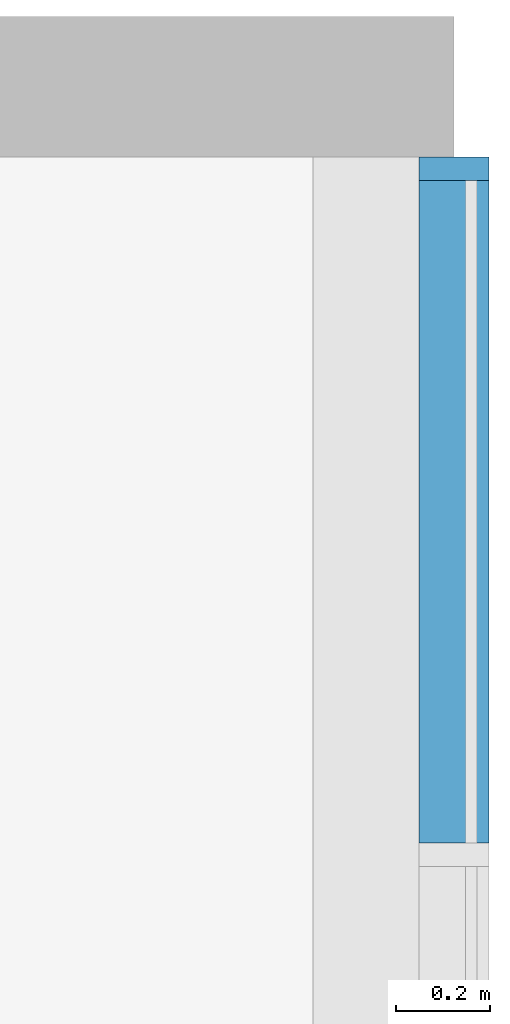
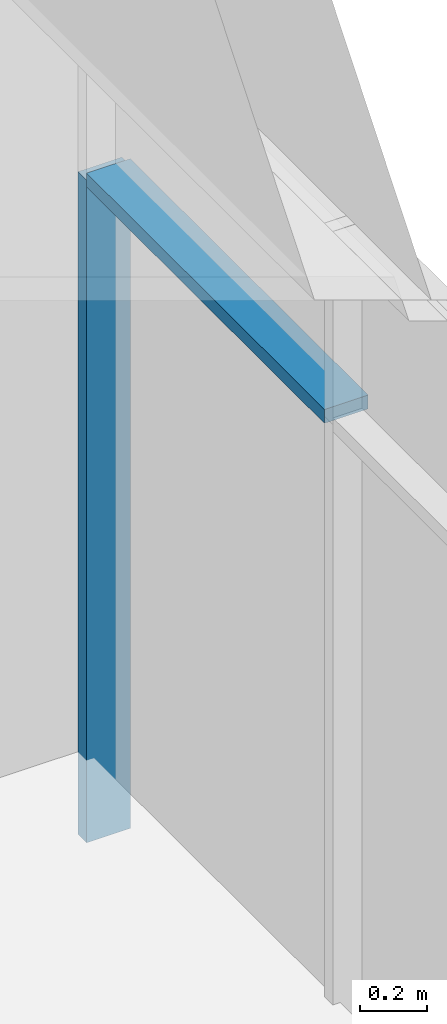
# One storey, part 3 of 13: 2 members, 1 element without a shape of its own.
"""IFC2X3 building model written with IfcOpenShell, lengths in millimetres."""

import ifcopenshell
import ifcopenshell.guid

model = None  # the IFC model being written
_history = None  # IfcOwnerHistory: only IFC2X3 demands one
_inside = {}  # id of a spatial element -> (the spatial element, [elements in it])
_under = {}  # id of a project, library or spatial element -> (it, [spatial elements below it])
_declared = {}  # id of a project -> (the project, [libraries it declares])
_typed = {}  # id of a type object -> (the type object, [elements of that type])
_made_of = {}  # id of a material, layer set ... -> (it, [elements and type objects made of it])


def new_model(schema):
    """Start an empty IFC model of exactly this schema.

    Asked for "IFC4X3", IfcOpenShell would pick the latest addendum, in which some entities
    have other attributes; the version numbers below select the first issue.
    IFC2X3 requires an IfcOwnerHistory on every rooted entity: one is made here for all.
    """
    global model, _history
    if schema == "IFC4X3":
        model = ifcopenshell.file(schema_version=(4, 3, 0, 0))
    else:
        model = ifcopenshell.file(schema=schema)
    _inside.clear()
    _under.clear()
    _declared.clear()
    _typed.clear()
    _made_of.clear()
    _history = None
    if model.schema == "IFC2X3":
        org = make("IfcOrganization", Name="unknown")
        user = make(
            "IfcPersonAndOrganization",
            ThePerson=make("IfcPerson", FamilyName="unknown"),
            TheOrganization=org,
        )
        app = make(
            "IfcApplication",
            ApplicationDeveloper=org,
            Version="unknown",
            ApplicationFullName="unknown",
            ApplicationIdentifier="unknown",
        )
        _history = make(
            "IfcOwnerHistory",
            OwningUser=user,
            OwningApplication=app,
            ChangeAction="ADDED",
            CreationDate=0,
        )
    return model


def make(cls, **values):
    """One entity of the class cls with the attributes given. An attribute that is None is left unset."""
    return model.create_entity(
        cls, **{name: value for name, value in values.items() if value is not None}
    )


def entity(cls, *values):
    """Any entity or typed value of the class cls, its attributes in the order of the schema. None: left unset."""
    e = model.create_entity(cls)
    for i, value in enumerate(values):
        if value is not None:
            e[i] = value
    return e


def rooted(cls, **values):
    """An entity with a GlobalId (a new one), such as an element, a storey or a relation."""
    return make(cls, GlobalId=ifcopenshell.guid.new(), OwnerHistory=_history, **values)


def si_unit(unit_type, name, prefix=None):
    """IfcSIUnit, for example si_unit("LENGTHUNIT", "METRE", prefix="MILLI")."""
    return make("IfcSIUnit", UnitType=unit_type, Prefix=prefix, Name=name)


def converted_unit(unit_type, name, factor, base, dimensions=None, offset=None):
    """IfcConversionBasedUnit, such as the inch: factor (a typed value) times the base unit."""
    return make(
        "IfcConversionBasedUnit"
        if offset is None
        else "IfcConversionBasedUnitWithOffset",
        ConversionOffset=offset,
        Dimensions=None
        if dimensions is None
        else entity("IfcDimensionalExponents", *dimensions),
        UnitType=unit_type,
        Name=name,
        ConversionFactor=make(
            "IfcMeasureWithUnit", ValueComponent=factor, UnitComponent=base
        ),
    )


def derived_unit(unit_type, elements):
    """IfcDerivedUnit: a product of units, each with its exponent."""
    return make(
        "IfcDerivedUnit",
        Elements=[
            make("IfcDerivedUnitElement", Unit=unit, Exponent=power)
            for unit, power in elements
        ],
        UnitType=unit_type,
    )


def assignment(units):
    """IfcUnitAssignment: the units of a project."""
    return None if units is None else make("IfcUnitAssignment", Units=units)


def point(xyz):
    """IfcCartesianPoint."""
    return None if xyz is None else make("IfcCartesianPoint", Coordinates=xyz)


def direction(xyz):
    """IfcDirection."""
    return None if xyz is None else make("IfcDirection", DirectionRatios=xyz)


def frame(location, z_axis=None, x_axis=None):
    """IfcAxis2Placement3D, a coordinate frame: its origin and axes. An axis left out is left unset."""
    return make(
        "IfcAxis2Placement3D",
        Location=point(location),
        Axis=direction(z_axis),
        RefDirection=direction(x_axis),
    )


def frame_2d(location, x_axis=None):
    """IfcAxis2Placement2D, a coordinate frame in the plane: its origin and x axis."""
    return make(
        "IfcAxis2Placement2D", Location=point(location), RefDirection=direction(x_axis)
    )


def origin():
    """The frame at (0, 0, 0) with its axes left unset."""
    return frame((0.0, 0.0, 0.0))


def origin_2d_with_axis():
    """The frame at (0, 0) in the plane with the x axis (1, 0) written out."""
    return frame_2d((0.0, 0.0), x_axis=(1.0, 0.0))


def place(relative_to, where):
    """IfcLocalPlacement: puts the frame where relative to a parent placement (None: the world)."""
    return make(
        "IfcLocalPlacement", PlacementRelTo=relative_to, RelativePlacement=where
    )


def context(
    kind, dimensions, precision=None, world=None, true_north=None, identifier=None
):
    """IfcGeometricRepresentationContext, for example the 3D "Model" context."""
    return make(
        "IfcGeometricRepresentationContext",
        ContextIdentifier=identifier,
        ContextType=kind,
        CoordinateSpaceDimension=dimensions,
        Precision=precision,
        WorldCoordinateSystem=world,
        TrueNorth=true_north,
    )


def subcontext(parent, identifier, kind, view, scale=None):
    """IfcGeometricRepresentationSubContext, for example "Body" below "Model"."""
    return make(
        "IfcGeometricRepresentationSubContext",
        ContextIdentifier=identifier,
        ContextType=kind,
        ParentContext=parent,
        TargetScale=scale,
        TargetView=view,
    )


def project(units=None, contexts=None):
    """IfcProject with its units and contexts."""
    return rooted(
        "IfcProject",
        Name="project",
        RepresentationContexts=contexts,
        UnitsInContext=assignment(units),
    )


def spatial(cls, under=None, at=None, **own):
    """A site, building, storey or space (cls), placed at a placement, below another one or the project."""
    s = rooted(cls, ObjectPlacement=at, **own)
    if under is not None:
        _under.setdefault(under.id(), (under, []))[1].append(s)
    return s


def profile(cls, at=None, kind="AREA", **sizes):
    """A parametric profile (cls). Its sizes go by their IFC names, for example OverallWidth=200.0."""
    return make(cls, ProfileType=kind, Position=at, **sizes)


def rectangle(**sizes):
    """IfcRectangleProfileDef."""
    return profile("IfcRectangleProfileDef", **sizes)


def extrude(swept, where, along, depth):
    """IfcExtrudedAreaSolid: the profile swept, set in the frame where, extruded along a direction by depth."""
    return make(
        "IfcExtrudedAreaSolid",
        SweptArea=swept,
        Position=where,
        ExtrudedDirection=direction(along),
        Depth=depth,
    )


def shape(context_of_items, identifier, shape_type, items):
    """IfcShapeRepresentation: the items that make up one representation, for example the "Body"."""
    return make(
        "IfcShapeRepresentation",
        ContextOfItems=context_of_items,
        RepresentationIdentifier=identifier,
        RepresentationType=shape_type,
        Items=items,
    )


def material(Name=None, Category=None):
    """IfcMaterial."""
    return make("IfcMaterial", Name=Name, Category=Category)


def made_of(thing, what):
    """Note that an element or type object is made of a material, layer set ...; save() writes the relation."""
    if what is not None:
        _made_of.setdefault(what.id(), (what, []))[1].append(thing)
    return thing


def type_object(cls, material=None, **own):
    """A type object (cls), such as IfcWallType, which elements share."""
    return made_of(rooted(cls, **own), material)


def element(
    cls,
    number,
    at=None,
    inside=None,
    cuts=None,
    type_object=None,
    material=None,
    context=None,
    identifier="Body",
    shape_type=None,
    held_by="IfcProductDefinitionShape",
    body=None,
    shapes=None,
    **own,
):
    """One element of the class cls, such as IfcWall. Its Tag is "e" and its number.

    at: its placement. inside: the storey or other place that contains it. cuts: it is an
    opening in that element (IfcRelVoidsElement). A single representation is given by context,
    identifier, shape_type and body (its items); several are given by shapes. held_by: the class
    of the entity that holds the representations. save() writes the other relations.
    """
    e = rooted(cls, Tag="e%d" % number, ObjectPlacement=at, **own)
    if body is not None:
        shapes = [shape(context, identifier, shape_type, body)]
    if shapes is not None:
        e.Representation = make(held_by, Representations=shapes)
    if inside is not None:
        _inside.setdefault(inside.id(), (inside, []))[1].append(e)
    if cuts is not None:
        rooted(
            "IfcRelVoidsElement", RelatingBuildingElement=cuts, RelatedOpeningElement=e
        )
    if type_object is not None:
        _typed.setdefault(type_object.id(), (type_object, []))[1].append(e)
    return made_of(e, material)


def aggregate(whole, parts):
    """IfcRelAggregates: a whole, such as a stair, and the parts it consists of."""
    return rooted("IfcRelAggregates", RelatingObject=whole, RelatedObjects=parts)


def save(model, path):
    """Write the relations noted so far, then the file.

    IfcRelAggregates (storeys below a building ...), IfcRelContainedInSpatialStructure (elements
    in a storey), IfcRelDefinesByType, IfcRelAssociatesMaterial and IfcRelDeclares: one each for
    every whole, place, type object, material and project.
    """
    for whole, parts in _under.values():
        aggregate(whole, parts)
    for where, things in _inside.values():
        rooted(
            "IfcRelContainedInSpatialStructure",
            RelatedElements=things,
            RelatingStructure=where,
        )
    for kind, things in _typed.values():
        rooted("IfcRelDefinesByType", RelatedObjects=things, RelatingType=kind)
    for what, things in _made_of.values():
        rooted("IfcRelAssociatesMaterial", RelatedObjects=things, RelatingMaterial=what)
    for by, libraries in _declared.values():
        rooted("IfcRelDeclares", RelatingContext=by, RelatedDefinitions=libraries)
    model.write(path)


model = new_model("IFC2X3")

# Units and contexts
model_context = context("Model", 3, precision=0.01, world=origin(), true_north=direction((6.12303176911189e-17, 1.0)))
context_of_model = context(None, 3, precision=0.01, world=origin(), true_north=direction((6.12303176911189e-17, 1.0)))
body_context = subcontext(model_context, "Body", "Model", "MODEL_VIEW")
ifc_project = project(units=[si_unit("LENGTHUNIT", "METRE", prefix="MILLI"), si_unit("AREAUNIT", "SQUARE_METRE"), si_unit("VOLUMEUNIT", "CUBIC_METRE"), converted_unit("PLANEANGLEUNIT", "DEGREE", entity("IfcRatioMeasure", 0.0174532925199433), si_unit("PLANEANGLEUNIT", "RADIAN"), dimensions=[0, 0, 0, 0, 0, 0, 0]), si_unit("MASSUNIT", "GRAM", prefix="KILO"), si_unit("TIMEUNIT", "SECOND"), si_unit("FREQUENCYUNIT", "HERTZ"), si_unit("THERMODYNAMICTEMPERATUREUNIT", "DEGREE_CELSIUS"), derived_unit("THERMALTRANSMITTANCEUNIT", [(si_unit("MASSUNIT", "GRAM", prefix="KILO"), 1), (si_unit("THERMODYNAMICTEMPERATUREUNIT", "KELVIN"), -1), (si_unit("TIMEUNIT", "SECOND"), -3)]), derived_unit("VOLUMETRICFLOWRATEUNIT", [(si_unit("LENGTHUNIT", "METRE"), 3), (si_unit("TIMEUNIT", "SECOND"), -1)]), si_unit("ELECTRICCURRENTUNIT", "AMPERE"), si_unit("ELECTRICVOLTAGEUNIT", "VOLT"), si_unit("POWERUNIT", "WATT"), si_unit("FORCEUNIT", "NEWTON", prefix="KILO"), si_unit("ILLUMINANCEUNIT", "LUX"), si_unit("LUMINOUSFLUXUNIT", "LUMEN"), si_unit("LUMINOUSINTENSITYUNIT", "CANDELA"), si_unit("PRESSUREUNIT", "PASCAL")], contexts=[model_context, context_of_model])

# Site, building, storey
site_placement = place(None, origin())
site = spatial("IfcSite", under=ifc_project, at=site_placement, CompositionType="ELEMENT")
building_placement = place(site_placement, origin())
building = spatial("IfcBuilding", under=site, at=building_placement, CompositionType="ELEMENT")
storey_placement = place(building_placement, frame((0.0, 0.0, 3750.0)))
storey = spatial("IfcBuildingStorey", under=building, at=storey_placement, Name="02. 2 etg.", CompositionType="ELEMENT", Elevation=3750.00000000068)

# Curtain wall, members
curtain_wall_type = type_object("IfcCurtainWallType", Name="Curtain Wall:Storefront", PredefinedType="NOTDEFINED")
curtain_wall_placement = place(storey_placement, frame((0.0, 0.0, -3750.0)))
curtain_wall = element("IfcCurtainWall", 1, at=curtain_wall_placement, inside=storey, type_object=curtain_wall_type, Name="Curtain Wall:Storefront", ObjectType="Curtain Wall:Storefront")
ifc_material = material(Name="Aluminium")
member_1_placement = place(curtain_wall_placement, frame((41023.2357123495, -110.0, 3450.0)))
member_1 = element("IfcMember", 2, at=member_1_placement, material=ifc_material, Name="Curtain Wall:Storefront:8486", ObjectType="Curtain Wall:Storefront:8486", context=body_context, shape_type="SweptSolid", body=[
    extrude(rectangle(XDim=50.0, YDim=150.000000000001, at=frame_2d((3.5527136788005e-15, 0.0), x_axis=(1.0, 0.0))), frame((75.0, 25.0, 0.0), z_axis=(0.0, 0.0, 1.0), x_axis=(0.0, -1.0, 0.0)), (0.0, 0.0, 1.0), 2400.0),
])
member_2_placement = place(curtain_wall_placement, frame((41023.2357123495, -1521.66666666667, 5825.0)))
member_2 = element("IfcMember", 3, at=member_2_placement, material=ifc_material, Name="Curtain Wall:Storefront:8486", ObjectType="Curtain Wall:Storefront:8486", context=body_context, shape_type="SweptSolid", body=[
    extrude(rectangle(XDim=1411.66666666667, YDim=150.000000000001, at=origin_2d_with_axis()), frame((75.0, 705.833333333333, 0.0), z_axis=(0.0, 0.0, 1.0), x_axis=(0.0, 1.0, 0.0)), (0.0, 0.0, 1.0), 49.9999999999995),
])
aggregate(curtain_wall, [member_1, member_2])

save(model, "model.ifc")
